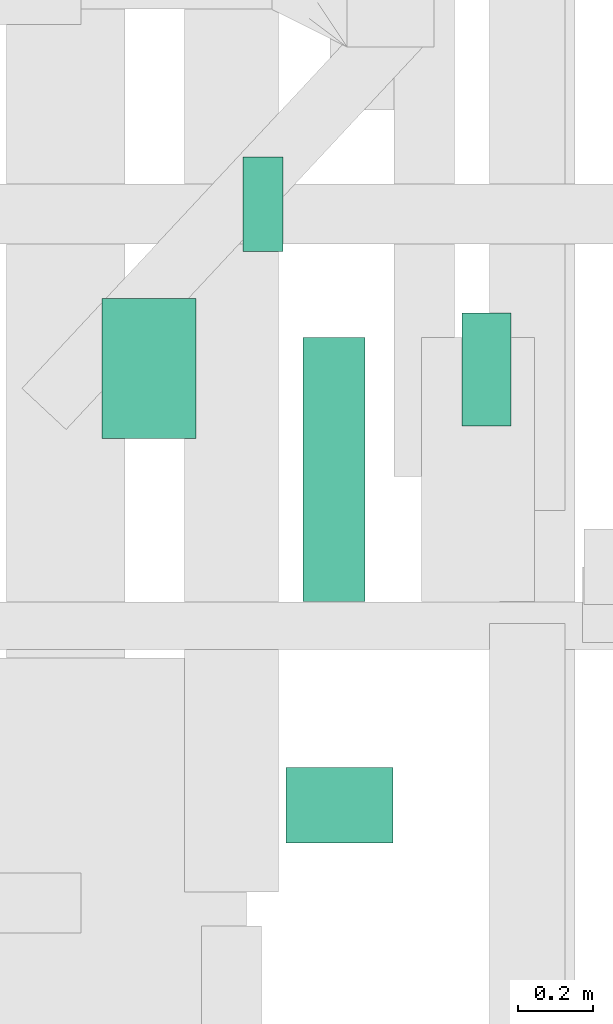
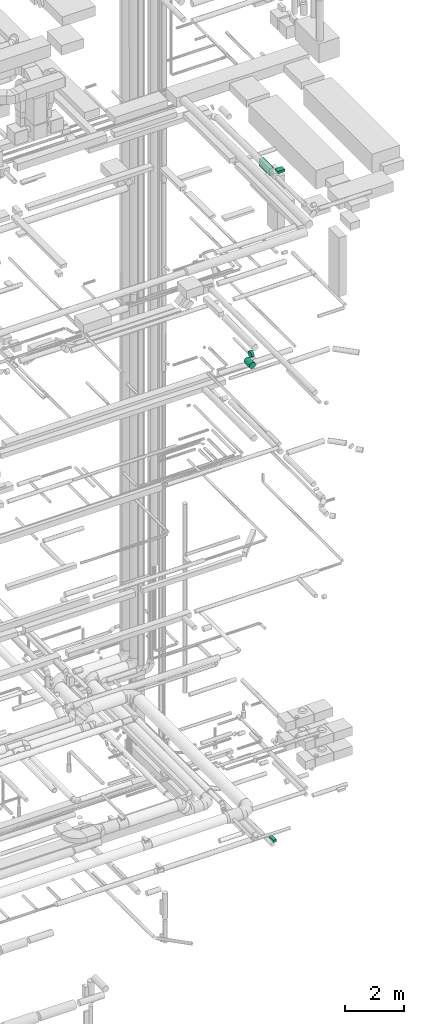
# One storey, part 215 of 337: 5 flow segments.
"""IFC2X3 building model written with IfcOpenShell, lengths in millimetres."""

from ifc_helpers import new_model, entity, si_unit, converted_unit, derived_unit, direction, frame, origin, origin_2d_with_axis, place, context, subcontext, project, spatial, rectangle, circle, extrude, type_object, element, save


model = new_model("IFC2X3")

# Units and contexts
model_context = context("Model", 3, precision=0.01, world=origin(), true_north=direction((6.12303176911189e-17, 1.0)))
body_context = subcontext(model_context, "Body", "Model", "MODEL_VIEW")
ifc_project = project(units=[si_unit("LENGTHUNIT", "METRE", prefix="MILLI"), si_unit("AREAUNIT", "SQUARE_METRE"), si_unit("VOLUMEUNIT", "CUBIC_METRE"), converted_unit("PLANEANGLEUNIT", "DEGREE", entity("IfcRatioMeasure", 0.0174532925199433), si_unit("PLANEANGLEUNIT", "RADIAN"), dimensions=[0, 0, 0, 0, 0, 0, 0]), si_unit("MASSUNIT", "GRAM", prefix="KILO"), derived_unit("MASSDENSITYUNIT", [(si_unit("MASSUNIT", "GRAM", prefix="KILO"), 1), (si_unit("LENGTHUNIT", "METRE"), -3)]), derived_unit("MOMENTOFINERTIAUNIT", [(si_unit("LENGTHUNIT", "METRE"), 4)]), si_unit("TIMEUNIT", "SECOND"), si_unit("FREQUENCYUNIT", "HERTZ"), si_unit("THERMODYNAMICTEMPERATUREUNIT", "DEGREE_CELSIUS"), derived_unit("THERMALTRANSMITTANCEUNIT", [(si_unit("MASSUNIT", "GRAM", prefix="KILO"), 1), (si_unit("THERMODYNAMICTEMPERATUREUNIT", "KELVIN"), -1), (si_unit("TIMEUNIT", "SECOND"), -3)]), derived_unit("VOLUMETRICFLOWRATEUNIT", [(si_unit("LENGTHUNIT", "METRE"), 3), (si_unit("TIMEUNIT", "SECOND"), -1)]), derived_unit("MASSFLOWRATEUNIT", [(si_unit("MASSUNIT", "GRAM", prefix="KILO"), 1), (si_unit("TIMEUNIT", "SECOND"), -1)]), derived_unit("ROTATIONALFREQUENCYUNIT", [(si_unit("TIMEUNIT", "SECOND"), -1)]), si_unit("ELECTRICCURRENTUNIT", "AMPERE"), si_unit("ELECTRICVOLTAGEUNIT", "VOLT"), si_unit("POWERUNIT", "WATT"), si_unit("FORCEUNIT", "NEWTON", prefix="KILO"), si_unit("ILLUMINANCEUNIT", "LUX"), si_unit("LUMINOUSFLUXUNIT", "LUMEN"), si_unit("LUMINOUSINTENSITYUNIT", "CANDELA"), derived_unit("USERDEFINED", [(si_unit("MASSUNIT", "GRAM", prefix="KILO"), -1), (si_unit("LENGTHUNIT", "METRE"), -2), (si_unit("TIMEUNIT", "SECOND"), 3), (si_unit("LUMINOUSFLUXUNIT", "LUMEN"), 1)]), derived_unit("LINEARVELOCITYUNIT", [(si_unit("LENGTHUNIT", "METRE"), 1), (si_unit("TIMEUNIT", "SECOND"), -1)]), si_unit("PRESSUREUNIT", "PASCAL"), derived_unit("USERDEFINED", [(si_unit("LENGTHUNIT", "METRE"), -2), (si_unit("MASSUNIT", "GRAM", prefix="KILO"), 1), (si_unit("TIMEUNIT", "SECOND"), -2)]), derived_unit("LINEARFORCEUNIT", [(si_unit("MASSUNIT", "GRAM", prefix="KILO"), 1), (si_unit("LENGTHUNIT", "METRE"), 1), (si_unit("TIMEUNIT", "SECOND"), -2), (si_unit("LENGTHUNIT", "METRE"), -1)]), derived_unit("PLANARFORCEUNIT", [(si_unit("MASSUNIT", "GRAM", prefix="KILO"), 1), (si_unit("LENGTHUNIT", "METRE"), 1), (si_unit("TIMEUNIT", "SECOND"), -2), (si_unit("LENGTHUNIT", "METRE"), -2)])], contexts=[model_context])

# Site, building, storey
site_placement = place(None, origin())
site = spatial("IfcSite", under=ifc_project, at=site_placement, CompositionType="ELEMENT")
building_placement = place(site_placement, origin())
building = spatial("IfcBuilding", under=site, at=building_placement, CompositionType="ELEMENT")
storey_placement = place(building_placement, origin())
storey = spatial("IfcBuildingStorey", under=building, at=storey_placement, CompositionType="ELEMENT", Elevation=0.0)

# Flow segments
duct_segment_type_1 = type_object("IfcDuctSegmentType", PredefinedType="NOTDEFINED")
flow_segment_1_placement = place(storey_placement, frame((69114.5, 5148.85, -850.0)))
element("IfcFlowSegment", 1, at=flow_segment_1_placement, inside=storey, type_object=duct_segment_type_1, context=body_context, shape_type="SweptSolid", body=[
    extrude(rectangle(XDim=129.999999999996, YDim=300.0, at=origin_2d_with_axis()), frame((65.0, 150.0, 0.0)), (0.0, 0.0, 1.0), 100.0),
])
flow_segment_2_placement = place(storey_placement, frame((68692.59, 4683.42, 27085.0)))
element("IfcFlowSegment", 2, at=flow_segment_2_placement, inside=storey, type_object=duct_segment_type_1, context=body_context, shape_type="SweptSolid", body=[
    extrude(rectangle(XDim=164.375000000082, YDim=700.0, at=origin_2d_with_axis()), frame((82.19, 350.0, 0.0)), (0.0, 0.0, 1.0), 300.000000000001),
])
flow_segment_3_placement = place(storey_placement, frame((68648.02, 4042.42, 27575.0)))
element("IfcFlowSegment", 3, at=flow_segment_3_placement, inside=storey, type_object=duct_segment_type_1, context=body_context, shape_type="SweptSolid", body=[
    extrude(rectangle(XDim=283.509978559025, YDim=200.0, at=origin_2d_with_axis()), frame((141.75, 100.0, 0.0)), (0.0, 0.0, 1.0), 100.000000000003),
])
duct_segment_type_2 = type_object("IfcDuctSegmentType", PredefinedType="NOTDEFINED")
flow_segment_4_placement = place(storey_placement, frame((68533.81, 5610.18, 19023.4)))
element("IfcFlowSegment", 4, at=flow_segment_4_placement, inside=storey, type_object=duct_segment_type_2, context=body_context, shape_type="SweptSolid", body=[
    extrude(circle(Radius=125.0, at=origin_2d_with_axis()), frame((0.0, 126.6, 126.6), z_axis=(1.0, 0.0, 0.0), x_axis=(0.0, 1.0, 0.0)), (0.0, 0.0, 1.0), 105.625000000004),
])
flow_segment_5_placement = place(storey_placement, frame((68157.21, 5115.53, 19023.4)))
element("IfcFlowSegment", 5, at=flow_segment_5_placement, inside=storey, type_object=duct_segment_type_2, context=body_context, shape_type="SweptSolid", body=[
    extrude(circle(Radius=125.0, at=origin_2d_with_axis()), frame((126.6, 0.0, 126.6), z_axis=(0.0, 1.0, 0.0), x_axis=(-1.0, 0.0, 0.0)), (0.0, 0.0, 1.0), 371.249999999987),
])

save(model, "model.ifc")
